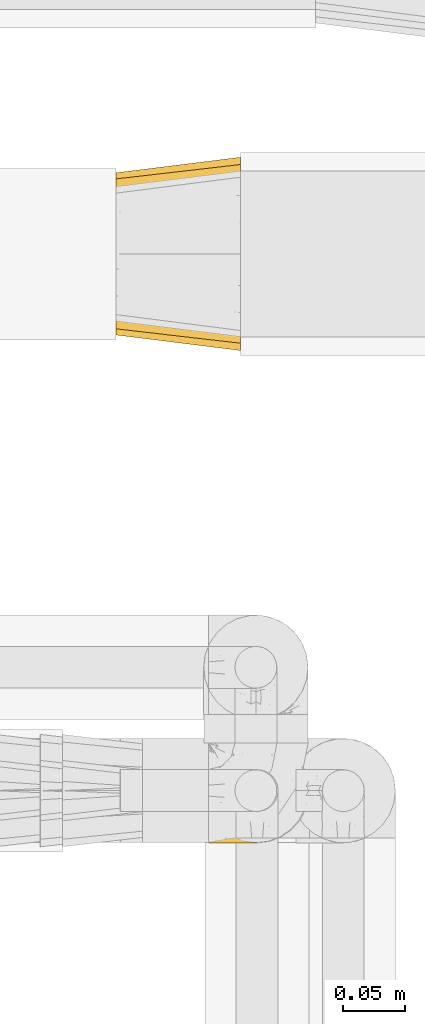
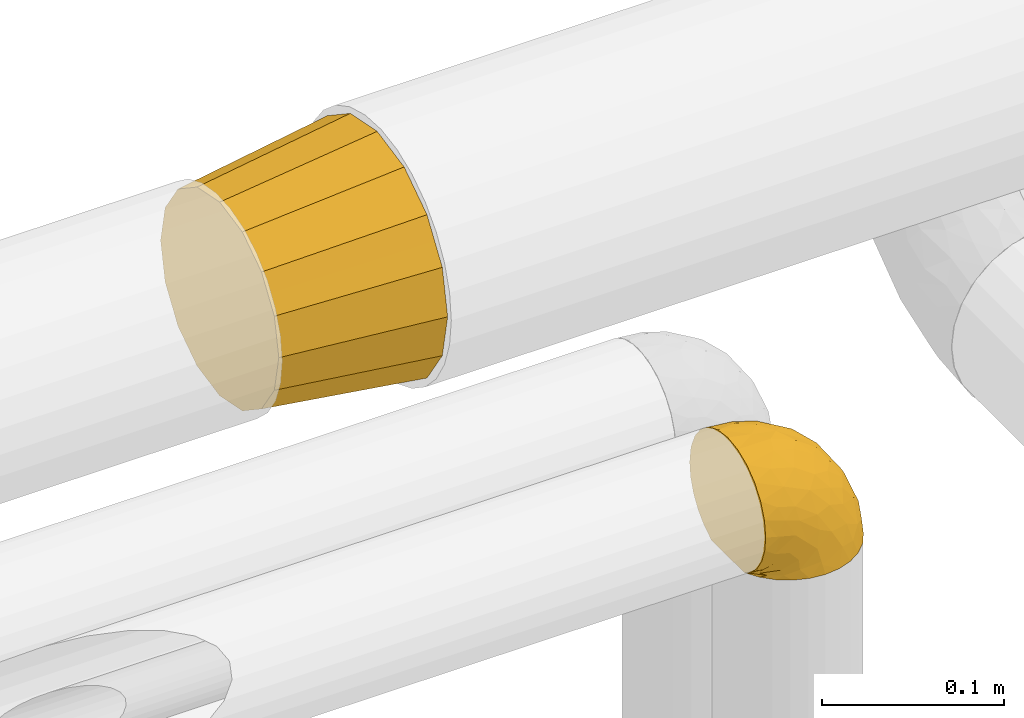
# One storey, part 454 of 827: 2 coverings.
"""IFC2X3 building model written with IfcOpenShell, lengths in millimetres."""

from ifc_helpers import new_model, entity, si_unit, converted_unit, derived_unit, direction, frame, origin, place, context, subcontext, project, spatial, faceted_brep, element, save


model = new_model("IFC2X3")

# Units and contexts
model_context = context("Model", 3, precision=0.01, world=origin(), true_north=direction((6.12303176911189e-17, 1.0)))
body_context = subcontext(model_context, "Body", "Model", "MODEL_VIEW")
ifc_project = project(units=[si_unit("LENGTHUNIT", "METRE", prefix="MILLI"), si_unit("AREAUNIT", "SQUARE_METRE"), si_unit("VOLUMEUNIT", "CUBIC_METRE"), converted_unit("PLANEANGLEUNIT", "DEGREE", entity("IfcRatioMeasure", 0.0174532925199433), si_unit("PLANEANGLEUNIT", "RADIAN"), dimensions=[0, 0, 0, 0, 0, 0, 0]), si_unit("MASSUNIT", "GRAM", prefix="KILO"), derived_unit("MASSDENSITYUNIT", [(si_unit("MASSUNIT", "GRAM", prefix="KILO"), 1), (si_unit("LENGTHUNIT", "METRE"), -3)]), derived_unit("MOMENTOFINERTIAUNIT", [(si_unit("LENGTHUNIT", "METRE"), 4)]), si_unit("TIMEUNIT", "SECOND"), si_unit("FREQUENCYUNIT", "HERTZ"), si_unit("THERMODYNAMICTEMPERATUREUNIT", "DEGREE_CELSIUS"), derived_unit("THERMALTRANSMITTANCEUNIT", [(si_unit("MASSUNIT", "GRAM", prefix="KILO"), 1), (si_unit("THERMODYNAMICTEMPERATUREUNIT", "KELVIN"), -1), (si_unit("TIMEUNIT", "SECOND"), -3)]), derived_unit("VOLUMETRICFLOWRATEUNIT", [(si_unit("LENGTHUNIT", "METRE"), 3), (si_unit("TIMEUNIT", "SECOND"), -1)]), derived_unit("MASSFLOWRATEUNIT", [(si_unit("MASSUNIT", "GRAM", prefix="KILO"), 1), (si_unit("TIMEUNIT", "SECOND"), -1)]), derived_unit("ROTATIONALFREQUENCYUNIT", [(si_unit("TIMEUNIT", "SECOND"), -1)]), si_unit("ELECTRICCURRENTUNIT", "AMPERE"), si_unit("ELECTRICVOLTAGEUNIT", "VOLT"), si_unit("POWERUNIT", "WATT"), si_unit("FORCEUNIT", "NEWTON", prefix="KILO"), si_unit("ILLUMINANCEUNIT", "LUX"), si_unit("LUMINOUSFLUXUNIT", "LUMEN"), si_unit("LUMINOUSINTENSITYUNIT", "CANDELA"), derived_unit("USERDEFINED", [(si_unit("MASSUNIT", "GRAM", prefix="KILO"), -1), (si_unit("LENGTHUNIT", "METRE"), -2), (si_unit("TIMEUNIT", "SECOND"), 3), (si_unit("LUMINOUSFLUXUNIT", "LUMEN"), 1)]), derived_unit("LINEARVELOCITYUNIT", [(si_unit("LENGTHUNIT", "METRE"), 1), (si_unit("TIMEUNIT", "SECOND"), -1)]), si_unit("PRESSUREUNIT", "PASCAL"), derived_unit("USERDEFINED", [(si_unit("LENGTHUNIT", "METRE"), -2), (si_unit("MASSUNIT", "GRAM", prefix="KILO"), 1), (si_unit("TIMEUNIT", "SECOND"), -2)]), derived_unit("LINEARFORCEUNIT", [(si_unit("MASSUNIT", "GRAM", prefix="KILO"), 1), (si_unit("LENGTHUNIT", "METRE"), 1), (si_unit("TIMEUNIT", "SECOND"), -2), (si_unit("LENGTHUNIT", "METRE"), -1)]), derived_unit("PLANARFORCEUNIT", [(si_unit("MASSUNIT", "GRAM", prefix="KILO"), 1), (si_unit("LENGTHUNIT", "METRE"), 1), (si_unit("TIMEUNIT", "SECOND"), -2), (si_unit("LENGTHUNIT", "METRE"), -2)])], contexts=[model_context])

# Site, building, storey
site_placement = place(None, origin())
site = spatial("IfcSite", under=ifc_project, at=site_placement, CompositionType="ELEMENT")
building_placement = place(site_placement, origin())
building = spatial("IfcBuilding", under=site, at=building_placement, CompositionType="ELEMENT")
storey_placement = place(building_placement, frame((0.0, 0.0, 28200.0)))
storey = spatial("IfcBuildingStorey", under=building, at=storey_placement, Name="08", CompositionType="ELEMENT", Elevation=28200.0)

# Coverings
covering_1_placement = place(storey_placement, frame((56451.05, 17851.0, 2820.87)))
element("IfcCovering", 1, at=covering_1_placement, inside=storey, Name=":ADSK_", ObjectType=":ADSK_", PredefinedType="INSULATION", context=body_context, shape_type="Brep", body=[
    faceted_brep([(0.0, 144.1, 79.1), (0.0, 141.62, 66.66), (0.0, 139.15, 54.22), (0.0, 132.1, 43.68), (0.0, 125.06, 33.13), (0.0, 114.51, 26.09), (0.0, 103.97, 19.04), (0.0, 91.53, 16.57), (0.0, 79.1, 14.1), (0.0, 66.66, 16.57), (0.0, 54.22, 19.04), (0.0, 43.68, 26.09), (0.0, 33.13, 33.13), (0.0, 26.09, 43.68), (0.0, 19.04, 54.22), (0.0, 16.57, 66.66), (0.0, 14.1, 79.1), (0.0, 16.57, 91.53), (0.0, 19.04, 103.97), (0.0, 26.09, 114.51), (0.0, 33.13, 125.06), (0.0, 43.68, 132.1), (0.0, 54.22, 139.15), (0.0, 66.66, 141.62), (0.0, 79.1, 144.1), (0.0, 91.53, 141.62), (0.0, 103.97, 139.15), (0.0, 114.51, 132.1), (0.0, 125.06, 125.06), (0.0, 132.1, 114.51), (0.0, 139.15, 103.97), (0.0, 141.62, 91.53), (100.0, 7.49, 108.75), (100.0, 4.54, 93.92), (100.0, 1.6, 79.1), (100.0, 5.43, 59.82), (100.0, 7.49, 49.44), (100.0, 15.89, 36.87), (100.0, 24.29, 24.29), (100.0, 36.87, 15.89), (100.0, 49.44, 7.49), (100.0, 64.27, 4.54), (100.0, 79.1, 1.6), (100.0, 98.37, 5.43), (100.0, 108.75, 7.49), (100.0, 121.32, 15.89), (100.0, 133.9, 24.29), (100.0, 142.3, 36.87), (100.0, 150.7, 49.44), (100.0, 153.65, 64.27), (100.0, 156.6, 79.1), (100.0, 152.76, 98.37), (100.0, 150.7, 108.75), (100.0, 142.3, 121.32), (100.0, 133.9, 133.9), (100.0, 121.32, 142.3), (100.0, 108.75, 150.7), (100.0, 93.92, 153.65), (100.0, 79.1, 156.6), (100.0, 59.82, 152.76), (100.0, 49.44, 150.7), (100.0, 36.87, 142.3), (100.0, 24.29, 133.9), (100.0, 15.89, 121.32)], [[[0, 1, 2, 3, 4, 5, 6, 7, 8, 9, 10, 11, 12, 13, 14, 15, 16, 17, 18, 19, 20, 21, 22, 23, 24, 25, 26, 27, 28, 29, 30, 31]], [[32, 33, 34, 35, 36, 37, 38, 39, 40, 41, 42, 43, 44, 45, 46, 47, 48, 49, 50, 51, 52, 53, 54, 55, 56, 57, 58, 59, 60, 61, 62, 63]], [[6, 44, 43, 42, 8, 7]], [[45, 44, 6, 5, 4, 46]], [[4, 3, 2, 48, 47, 46]], [[0, 50, 49, 48, 2, 1]], [[14, 36, 35, 34, 16, 15]], [[37, 36, 14, 13, 12, 38]], [[12, 11, 10, 40, 39, 38]], [[8, 42, 41, 40, 10, 9]], [[22, 60, 59, 58, 24, 23]], [[61, 60, 22, 21, 20, 62]], [[20, 19, 18, 32, 63, 62]], [[16, 34, 33, 32, 18, 17]], [[30, 52, 51, 50, 0, 31]], [[53, 52, 30, 29, 28, 54]], [[28, 27, 26, 56, 55, 54]], [[24, 58, 57, 56, 26, 25]]]),
])
covering_2_placement = place(storey_placement, frame((56523.63, 17456.55, 2960.4)))
element("IfcCovering", 2, at=covering_2_placement, inside=storey, Name=":ADSK_", ObjectType=":ADSK_", PredefinedType="INSULATION", context=body_context, shape_type="Brep", body=[
    faceted_brep([(57.76, 81.15, 1.6), (65.69, 76.16, 1.6), (72.32, 69.53, 1.6), (77.3, 61.6, 1.6), (80.4, 52.75, 1.6), (81.45, 43.45, 1.6), (80.39, 34.13, 1.6), (77.3, 25.28, 1.6), (72.31, 17.35, 1.6), (65.68, 10.72, 1.6), (57.75, 5.74, 1.6), (48.9, 2.64, 1.6), (39.6, 1.6, 1.6), (30.22, 2.66, 1.6), (21.33, 5.79, 1.6), (13.37, 10.83, 1.6), (6.73, 17.53, 1.6), (1.77, 25.53, 1.6), (1.77, 26.45, 1.6), (1.77, 27.37, 1.6), (1.77, 28.17, 1.6), (1.77, 29.49, 1.6), (1.77, 30.81, 1.6), (1.77, 32.13, 1.6), (1.77, 33.45, 1.6), (1.77, 34.78, 1.6), (1.77, 36.1, 1.6), (1.77, 37.42, 1.6), (1.77, 38.74, 1.6), (1.77, 40.06, 1.6), (1.77, 41.38, 1.6), (1.77, 42.7, 1.6), (1.77, 44.02, 1.6), (1.77, 45.34, 1.6), (1.77, 46.66, 1.6), (1.77, 47.58, 1.6), (1.77, 48.5, 1.6), (1.77, 49.41, 1.6), (1.77, 50.33, 1.6), (1.77, 51.25, 1.6), (1.77, 52.17, 1.6), (1.77, 53.09, 1.6), (1.77, 54.01, 1.6), (1.77, 54.93, 1.6), (1.77, 55.85, 1.6), (1.77, 56.76, 1.6), (1.77, 57.68, 1.6), (1.77, 58.6, 1.6), (1.77, 59.52, 1.6), (1.77, 60.44, 1.6), (1.77, 61.36, 1.6), (6.74, 69.37, 1.6), (13.38, 76.07, 1.6), (21.35, 81.11, 1.6), (30.24, 84.24, 1.6), (39.6, 85.3, 1.6), (48.91, 84.24, 1.6), (1.6, 17.52, 6.74), (1.6, 10.83, 13.37), (1.6, 5.79, 21.34), (1.6, 2.66, 30.23), (1.6, 1.6, 39.6), (1.6, 3.02, 50.43), (1.6, 7.2, 60.52), (1.6, 13.85, 69.19), (1.6, 22.52, 75.84), (1.6, 32.61, 80.02), (1.6, 43.45, 81.45), (1.6, 54.28, 80.02), (1.6, 64.37, 75.84), (1.6, 73.04, 69.19), (1.6, 79.69, 60.52), (1.6, 83.87, 50.43), (1.6, 85.3, 39.6), (1.6, 84.23, 30.23), (1.6, 81.1, 21.34), (1.6, 76.06, 13.37), (1.6, 69.37, 6.74), (1.6, 61.36, 1.77), (1.6, 60.44, 1.77), (1.6, 59.12, 1.77), (1.6, 58.0, 1.77), (1.6, 56.88, 1.77), (1.6, 55.76, 1.77), (1.6, 54.64, 1.77), (1.6, 53.52, 1.77), (1.6, 52.4, 1.77), (1.6, 51.28, 1.77), (1.6, 50.16, 1.77), (1.6, 49.04, 1.77), (1.6, 47.92, 1.77), (1.6, 46.8, 1.77), (1.6, 45.68, 1.77), (1.6, 44.56, 1.77), (1.6, 43.45, 1.77), (1.6, 42.12, 1.77), (1.6, 40.8, 1.77), (1.6, 39.48, 1.77), (1.6, 38.16, 1.77), (1.6, 36.84, 1.77), (1.6, 35.52, 1.77), (1.6, 34.2, 1.77), (1.6, 32.88, 1.77), (1.6, 31.96, 1.77), (1.6, 31.05, 1.77), (1.6, 30.13, 1.77), (1.6, 29.21, 1.77), (1.6, 28.29, 1.77), (1.6, 27.37, 1.77), (1.6, 26.45, 1.77), (1.6, 25.53, 1.77), (1.71, 54.08, 1.73), (1.73, 55.16, 1.72), (1.71, 36.18, 1.73), (1.72, 35.13, 1.72), (1.71, 44.01, 1.73), (1.72, 45.08, 1.73), (1.72, 61.36, 1.72), (1.72, 59.98, 1.72), (1.72, 46.18, 1.72), (1.72, 26.74, 1.72), (1.72, 47.36, 1.72), (1.72, 29.67, 1.73), (1.7, 28.72, 1.74), (1.72, 39.77, 1.72), (1.73, 52.96, 1.71), (1.72, 51.84, 1.73), (1.73, 40.8, 1.71), (1.73, 41.87, 1.72), (1.72, 42.94, 1.73), (1.72, 27.77, 1.72), (1.71, 48.4, 1.73), (1.72, 37.21, 1.72), (1.71, 33.54, 1.73), (1.72, 32.49, 1.72), (1.72, 30.69, 1.72), (1.72, 50.69, 1.72), (1.73, 49.6, 1.71), (1.72, 56.32, 1.72), (1.71, 57.44, 1.73), (1.73, 58.88, 1.71), (1.72, 25.53, 1.72), (1.74, 61.36, 1.68), (1.75, 61.36, 1.64), (1.75, 25.53, 1.64), (1.74, 25.53, 1.68), (1.64, 61.36, 1.75), (1.68, 61.36, 1.74), (1.68, 25.53, 1.74), (1.64, 25.53, 1.75), (1.74, 31.59, 1.7), (1.71, 38.71, 1.73), (8.98, 3.97, 24.54), (37.05, 1.6, 11.1), (24.69, 3.97, 8.47), (15.28, 8.09, 9.11), (16.86, 8.09, 4.86), (6.58, 16.43, 5.0), (5.71, 15.73, 6.81), (11.1, 1.6, 37.05), (10.79, 10.79, 9.03), (4.13, 13.99, 9.47), (6.62, 8.08, 16.39), (9.52, 14.0, 3.95), (6.14, 12.83, 9.9), (17.79, 3.18, 22.7), (20.6, 1.6, 34.5), (8.73, 1.6, 37.68), (23.66, 3.28, 15.82), (34.5, 1.6, 20.6), (15.32, 6.28, 14.37), (27.55, 1.6, 27.55), (3.31, 19.06, 5.2), (9.81, 8.08, 14.88), (37.68, 1.6, 8.73), (67.23, 32.11, 44.27), (76.64, 29.62, 20.94), (75.37, 43.45, 32.15), (14.58, 2.45, 46.13), (23.71, 2.5, 42.67), (34.34, 9.73, 55.18), (29.1, 17.97, 67.27), (18.02, 10.24, 62.91), (22.27, 4.78, 51.5), (10.97, 4.78, 54.79), (56.79, 8.01, 25.78), (60.76, 8.01, 13.05), (67.04, 13.85, 18.46), (36.11, 2.42, 32.4), (68.85, 21.17, 31.07), (24.58, 35.73, 77.32), (21.54, 27.43, 75.62), (78.4, 43.45, 16.9), (14.11, 17.97, 71.69), (53.42, 35.71, 61.4), (58.19, 29.47, 54.47), (44.49, 3.41, 27.66), (51.77, 3.94, 14.53), (73.69, 21.17, 15.56), (45.89, 7.92, 42.26), (35.97, 4.25, 41.51), (56.55, 11.75, 36.93), (60.03, 18.31, 42.72), (63.64, 24.94, 44.68), (34.98, 28.78, 71.2), (40.58, 35.82, 70.48), (32.15, 43.45, 75.37), (47.26, 28.38, 63.65), (58.06, 43.45, 58.06), (66.71, 43.45, 45.11), (16.9, 43.45, 78.4), (52.08, 21.21, 54.95), (41.21, 16.48, 59.31), (49.76, 13.85, 49.01), (45.11, 43.45, 66.71), (15.65, 82.11, 53.75), (24.57, 51.41, 77.27), (50.54, 57.45, 61.6), (67.25, 54.78, 44.24), (67.06, 73.03, 18.46), (73.7, 65.7, 15.55), (26.13, 76.65, 60.14), (19.54, 68.92, 70.5), (38.96, 68.01, 63.0), (56.8, 78.88, 25.78), (60.77, 78.88, 13.05), (51.78, 82.94, 14.53), (59.09, 64.44, 48.5), (19.25, 84.49, 44.23), (20.6, 85.3, 34.5), (11.1, 85.3, 37.05), (37.68, 85.3, 8.73), (15.21, 57.84, 77.68), (12.76, 76.65, 64.08), (40.93, 51.19, 70.25), (76.65, 57.26, 20.93), (39.5, 78.14, 49.9), (25.01, 82.35, 49.6), (68.86, 65.7, 31.06), (26.7, 84.61, 39.62), (34.95, 84.36, 34.42), (34.5, 85.3, 20.6), (27.55, 85.3, 27.55), (61.27, 73.03, 33.36), (44.5, 83.48, 27.68), (37.05, 85.3, 11.1), (10.25, 84.54, 46.67), (49.78, 73.03, 49.0), (47.51, 79.54, 38.94), (29.38, 59.46, 73.05), (40.01, 73.5, 56.63), (33.36, 82.57, 43.85), (8.98, 82.92, 24.54), (23.67, 83.62, 15.82), (24.71, 82.92, 8.47), (15.29, 78.81, 9.12), (4.13, 72.9, 9.47), (6.14, 74.06, 9.91), (4.96, 78.81, 16.85), (9.81, 78.81, 14.88), (3.31, 67.83, 5.2), (5.7, 71.15, 6.81), (9.53, 72.91, 3.96), (6.59, 70.47, 5.0), (16.63, 78.81, 5.86), (15.34, 80.62, 14.38), (10.8, 76.11, 9.04), (17.79, 83.71, 22.7)], [[[0, 1, 2, 3, 4, 5, 6, 7, 8, 9, 10, 11, 12, 13, 14, 15, 16, 17, 18, 19, 20, 21, 22, 23, 24, 25, 26, 27, 28, 29, 30, 31, 32, 33, 34, 35, 36, 37, 38, 39, 40, 41, 42, 43, 44, 45, 46, 47, 48, 49, 50, 51, 52, 53, 54, 55, 56]], [[57, 58, 59, 60, 61, 62, 63, 64, 65, 66, 67, 68, 69, 70, 71, 72, 73, 74, 75, 76, 77, 78, 79, 80, 81, 82, 83, 84, 85, 86, 87, 88, 89, 90, 91, 92, 93, 94, 95, 96, 97, 98, 99, 100, 101, 102, 103, 104, 105, 106, 107, 108, 109, 110]], [[111, 84, 112]], [[113, 26, 114]], [[114, 101, 100]], [[115, 93, 116]], [[79, 117, 118]], [[33, 116, 119]], [[117, 49, 118]], [[19, 18, 120]], [[119, 121, 34]], [[122, 21, 123]], [[97, 96, 124]], [[86, 125, 126]], [[116, 92, 119]], [[127, 96, 128]], [[32, 129, 115]], [[19, 120, 130]], [[121, 90, 131]], [[94, 115, 129]], [[115, 116, 32]], [[118, 49, 48]], [[113, 99, 132]], [[133, 114, 25]], [[24, 134, 133]], [[135, 22, 122]], [[136, 137, 88]], [[84, 83, 112]], [[138, 82, 139]], [[130, 20, 19]], [[118, 48, 140]], [[81, 140, 139]], [[123, 21, 20]], [[141, 120, 18]], [[139, 82, 81]], [[130, 107, 123]], [[49, 117, 142, 143, 50]], [[18, 17, 144, 145, 141]], [[79, 78, 146, 147, 117]], [[109, 141, 148, 149, 110]], [[102, 133, 134]], [[105, 135, 122]], [[118, 80, 79]], [[80, 118, 140]], [[120, 109, 108]], [[47, 46, 140, 48]], [[81, 80, 140]], [[44, 112, 138]], [[93, 115, 94]], [[46, 139, 140]], [[46, 45, 139]], [[139, 45, 138]], [[138, 112, 83]], [[85, 84, 111]], [[112, 43, 111]], [[83, 82, 138]], [[106, 122, 123]], [[105, 122, 106]], [[21, 122, 22]], [[124, 29, 28]], [[33, 32, 116]], [[128, 129, 31]], [[32, 31, 129]], [[34, 33, 119]], [[116, 93, 92]], [[129, 95, 94]], [[95, 129, 128]], [[41, 40, 125, 42]], [[119, 91, 121]], [[36, 35, 131, 37]], [[137, 131, 89]], [[121, 131, 35]], [[90, 121, 91]], [[119, 92, 91]], [[136, 126, 39]], [[125, 86, 85]], [[42, 125, 111]], [[85, 111, 125]], [[150, 23, 22]], [[130, 108, 107]], [[130, 123, 20]], [[107, 106, 123]], [[137, 37, 131]], [[136, 38, 137]], [[89, 88, 137]], [[131, 90, 89]], [[124, 151, 97]], [[40, 39, 126]], [[87, 126, 136]], [[86, 126, 87]], [[136, 88, 87]], [[40, 126, 125]], [[39, 38, 136]], [[95, 128, 96]], [[30, 128, 31]], [[29, 124, 127]], [[127, 128, 30]], [[151, 124, 28]], [[127, 30, 29]], [[127, 124, 96]], [[151, 98, 97]], [[45, 44, 138]], [[26, 113, 132]], [[113, 100, 99]], [[132, 151, 27]], [[27, 26, 132]], [[26, 25, 114]], [[100, 113, 114]], [[101, 133, 102]], [[133, 101, 114]], [[28, 27, 151]], [[132, 99, 98]], [[23, 134, 24]], [[25, 24, 133]], [[134, 23, 150]], [[135, 104, 150]], [[150, 104, 103]], [[103, 102, 134]], [[130, 120, 108]], [[109, 120, 141]], [[42, 111, 43]], [[112, 44, 43]], [[104, 135, 105]], [[134, 150, 103]], [[135, 150, 22]], [[35, 34, 121]], [[137, 38, 37]], [[98, 151, 132]], [[59, 152, 60]], [[13, 153, 154]], [[155, 156, 154]], [[157, 158, 141]], [[159, 60, 152]], [[160, 157, 155]], [[161, 162, 58]], [[58, 162, 59]], [[144, 16, 163]], [[58, 57, 161]], [[162, 161, 164]], [[157, 163, 155]], [[163, 16, 15]], [[57, 149, 161]], [[152, 165, 166]], [[157, 144, 163]], [[60, 159, 167, 61]], [[156, 14, 154]], [[163, 156, 155]], [[155, 154, 168]], [[168, 154, 169]], [[155, 170, 160]], [[57, 110, 149]], [[144, 17, 16]], [[156, 15, 14]], [[171, 165, 168]], [[158, 164, 172]], [[14, 13, 154]], [[157, 141, 145, 144]], [[173, 164, 158]], [[173, 160, 170]], [[171, 166, 165]], [[168, 165, 170]], [[168, 169, 171]], [[152, 173, 165]], [[170, 155, 168]], [[165, 173, 170]], [[160, 173, 158]], [[172, 149, 148]], [[148, 141, 158]], [[158, 157, 160]], [[152, 166, 159]], [[173, 152, 162]], [[59, 162, 152]], [[13, 12, 174, 153]], [[153, 169, 154]], [[15, 156, 163]], [[162, 164, 173]], [[172, 164, 161]], [[149, 172, 161]], [[158, 172, 148]], [[175, 176, 177]], [[178, 166, 179]], [[180, 181, 182]], [[183, 184, 178]], [[185, 186, 187]], [[171, 188, 179]], [[174, 12, 11]], [[189, 176, 175]], [[190, 66, 191]], [[176, 6, 192]], [[193, 65, 64]], [[63, 184, 182]], [[63, 182, 64]], [[65, 193, 191]], [[184, 63, 62]], [[175, 194, 195]], [[196, 169, 197]], [[174, 11, 197]], [[8, 7, 198]], [[187, 9, 8]], [[197, 169, 153, 174]], [[197, 11, 10]], [[186, 197, 10]], [[199, 180, 200]], [[197, 185, 196]], [[201, 189, 202]], [[201, 187, 189]], [[195, 203, 175]], [[191, 204, 190]], [[176, 7, 6]], [[177, 176, 192]], [[189, 198, 176]], [[65, 191, 66]], [[198, 187, 8]], [[205, 206, 190]], [[9, 186, 10]], [[181, 207, 204]], [[208, 175, 177, 209]], [[66, 190, 210]], [[211, 212, 213]], [[190, 204, 205]], [[180, 182, 183]], [[193, 182, 181]], [[62, 61, 167]], [[196, 185, 199]], [[196, 200, 188]], [[6, 5, 192]], [[176, 198, 7]], [[187, 198, 189]], [[187, 186, 9]], [[197, 186, 185]], [[200, 180, 183]], [[180, 213, 212]], [[179, 183, 178]], [[185, 201, 199]], [[210, 190, 206]], [[210, 67, 66]], [[205, 204, 207]], [[194, 205, 207]], [[194, 214, 205]], [[195, 194, 207]], [[208, 194, 175]], [[207, 211, 195]], [[202, 203, 211]], [[212, 207, 181]], [[202, 211, 213]], [[201, 202, 213]], [[189, 175, 203]], [[199, 201, 213]], [[187, 201, 185]], [[180, 199, 213]], [[196, 199, 200]], [[211, 203, 195]], [[189, 203, 202]], [[207, 212, 211]], [[180, 212, 181]], [[214, 194, 208]], [[214, 206, 205]], [[196, 188, 169]], [[181, 204, 191]], [[182, 193, 64]], [[191, 193, 181]], [[178, 62, 167]], [[182, 184, 183]], [[62, 178, 184]], [[178, 167, 159, 166]], [[171, 179, 166]], [[200, 183, 179]], [[179, 188, 200]], [[169, 188, 171]], [[71, 215, 72]], [[206, 216, 210]], [[217, 208, 218]], [[216, 68, 210]], [[219, 220, 2]], [[221, 222, 223]], [[224, 225, 226]], [[227, 223, 217]], [[228, 229, 230]], [[56, 231, 226]], [[232, 222, 69]], [[56, 55, 231]], [[70, 233, 71]], [[71, 233, 215]], [[0, 56, 226]], [[208, 217, 234]], [[218, 177, 235]], [[221, 236, 237]], [[238, 220, 219]], [[1, 219, 2]], [[68, 216, 232]], [[235, 3, 220]], [[235, 192, 4]], [[1, 0, 225]], [[228, 239, 229]], [[240, 241, 242]], [[243, 238, 219]], [[224, 226, 244]], [[226, 241, 244]], [[3, 235, 4]], [[69, 222, 70]], [[225, 219, 1]], [[218, 235, 238]], [[243, 219, 224]], [[218, 227, 217]], [[3, 2, 220]], [[218, 208, 209, 177]], [[226, 231, 245, 241]], [[215, 228, 246]], [[247, 248, 236]], [[248, 224, 244]], [[223, 222, 249]], [[233, 222, 221]], [[242, 239, 240]], [[248, 247, 243]], [[217, 223, 249]], [[250, 247, 236]], [[216, 234, 249]], [[218, 238, 227]], [[192, 235, 177]], [[192, 5, 4]], [[72, 246, 73]], [[235, 220, 238]], [[226, 225, 0]], [[219, 225, 224]], [[240, 248, 244]], [[239, 242, 229]], [[236, 248, 251]], [[68, 67, 210]], [[234, 216, 206]], [[216, 249, 232]], [[234, 206, 214, 208]], [[249, 234, 217]], [[222, 232, 249]], [[69, 68, 232]], [[246, 228, 230]], [[237, 228, 215]], [[243, 227, 238]], [[223, 227, 247]], [[73, 246, 230]], [[215, 246, 72]], [[248, 243, 224]], [[227, 243, 247]], [[237, 236, 251]], [[250, 221, 223]], [[222, 233, 70]], [[215, 233, 221]], [[221, 237, 215]], [[239, 237, 251]], [[237, 239, 228]], [[239, 251, 240]], [[248, 240, 251]], [[241, 240, 244]], [[221, 250, 236]], [[223, 247, 250]], [[74, 230, 252]], [[253, 254, 255]], [[146, 77, 256]], [[257, 258, 259]], [[260, 256, 257]], [[260, 261, 147]], [[75, 74, 252]], [[51, 143, 262]], [[263, 143, 142, 117]], [[256, 77, 76]], [[252, 258, 75]], [[253, 241, 254]], [[254, 245, 54]], [[258, 256, 76]], [[53, 52, 264]], [[255, 265, 253]], [[254, 264, 255]], [[255, 264, 262]], [[75, 258, 76]], [[265, 255, 266]], [[255, 262, 263]], [[51, 50, 143]], [[54, 245, 231, 55]], [[51, 262, 52]], [[253, 267, 242]], [[254, 54, 53]], [[266, 259, 265]], [[146, 78, 77]], [[263, 117, 261]], [[146, 256, 260]], [[257, 259, 261]], [[267, 253, 265]], [[229, 267, 252]], [[242, 267, 229]], [[242, 241, 253]], [[252, 267, 259]], [[255, 263, 266]], [[259, 267, 265]], [[261, 117, 147]], [[263, 261, 266]], [[259, 266, 261]], [[230, 74, 73]], [[230, 229, 252]], [[259, 258, 252]], [[254, 241, 245]], [[53, 264, 254]], [[52, 262, 264]], [[143, 263, 262]], [[258, 257, 256]], [[261, 260, 257]], [[146, 260, 147]]]),
])

save(model, "model.ifc")
